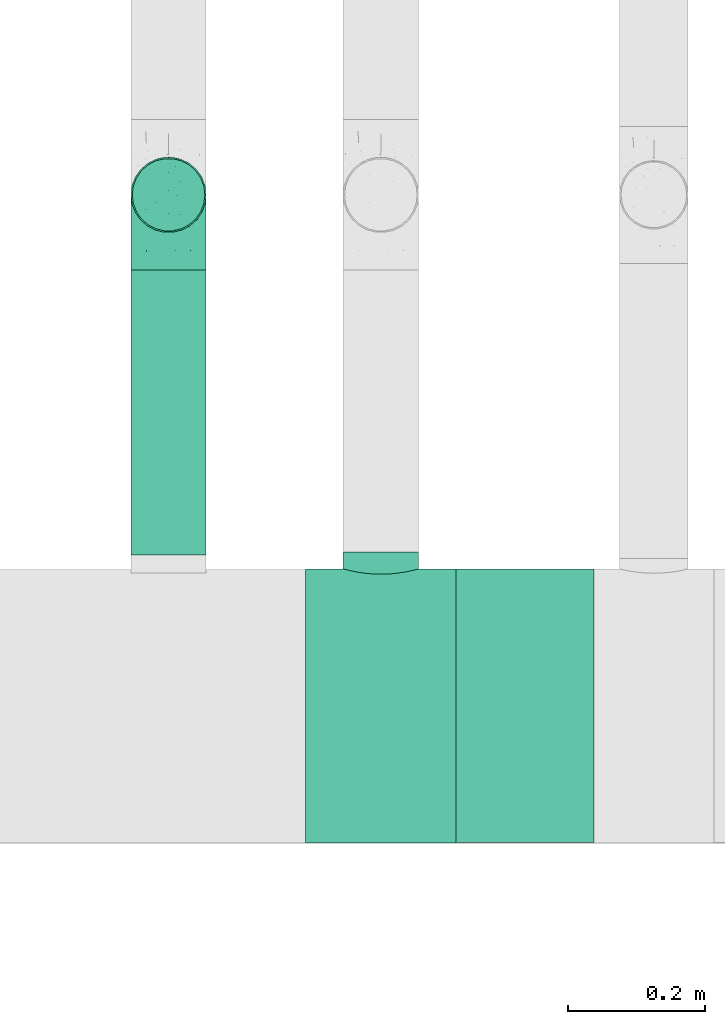
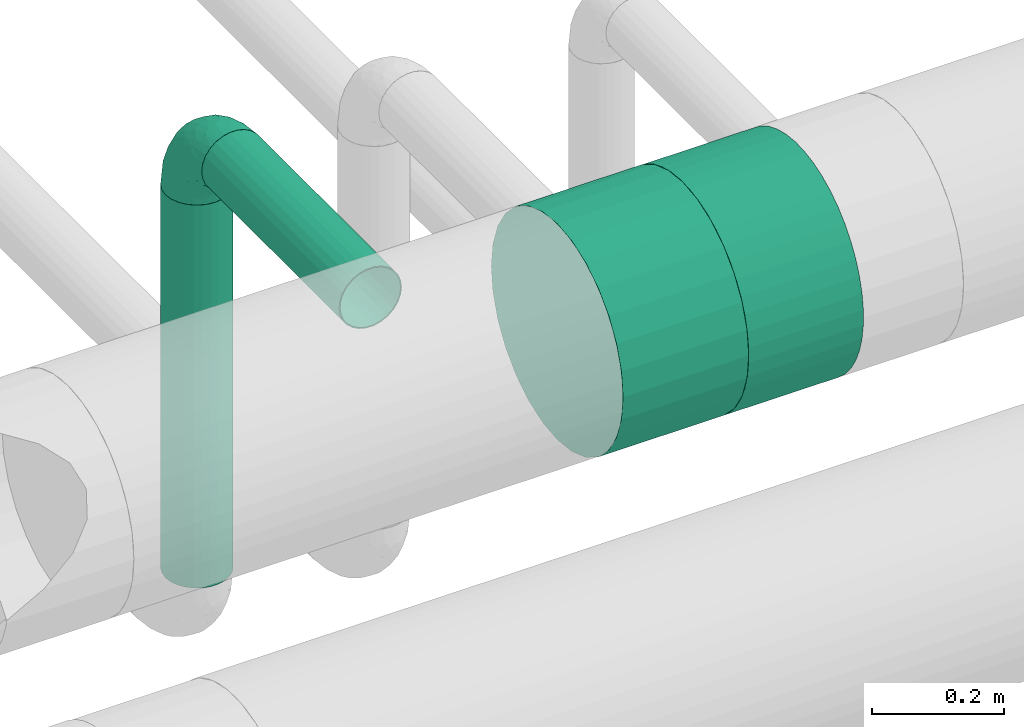
# One storey, part 80 of 91: 3 flow segments, 2 flow fittings.
"""IFC2X3 building model written with IfcOpenShell, lengths in millimetres."""

from ifc_helpers import new_model, entity, si_unit, converted_unit, derived_unit, direction, frame, origin_with_axes, origin_2d_with_axis, place, context, subcontext, project, spatial, hollow_circle, extrude, open_shell, surface_model, source, transform, mapped, material, layer, layer_set, layer_usage, type_object, element, save


model = new_model("IFC2X3")

# Units and contexts
model_context = context("Model", 3, precision=1e-05, world=origin_with_axes(), true_north=direction((0.0, 1.0)))
body_context = subcontext(model_context, "Body", "Model", "MODEL_VIEW")
ifc_project = project(units=[si_unit("AREAUNIT", "SQUARE_METRE"), si_unit("VOLUMEUNIT", "CUBIC_METRE", prefix="DECI"), si_unit("TIMEUNIT", "SECOND"), si_unit("THERMODYNAMICTEMPERATUREUNIT", "DEGREE_CELSIUS"), si_unit("PRESSUREUNIT", "PASCAL"), si_unit("MASSUNIT", "GRAM", prefix="KILO"), si_unit("LENGTHUNIT", "METRE", prefix="MILLI"), si_unit("POWERUNIT", "WATT"), si_unit("ELECTRICCURRENTUNIT", "AMPERE"), si_unit("ELECTRICVOLTAGEUNIT", "VOLT"), derived_unit("VOLUMETRICFLOWRATEUNIT", [(si_unit("VOLUMEUNIT", "CUBIC_METRE", prefix="DECI"), 1), (si_unit("TIMEUNIT", "SECOND"), -1)]), derived_unit("LINEARVELOCITYUNIT", [(si_unit("LENGTHUNIT", "METRE"), 1), (si_unit("TIMEUNIT", "SECOND"), -1)]), derived_unit("MASSDENSITYUNIT", [(si_unit("MASSUNIT", "GRAM", prefix="KILO"), 1), (si_unit("VOLUMEUNIT", "CUBIC_METRE"), -1)]), converted_unit("PLANEANGLEUNIT", "DEGREE", entity("IfcRatioMeasure", 0.01745), si_unit("PLANEANGLEUNIT", "RADIAN"), dimensions=[0, 0, 0, 0, 0, 0, 0])], contexts=[model_context])

# Site, building, storey
site_placement = place(None, origin_with_axes())
site = spatial("IfcSite", under=ifc_project, at=site_placement, CompositionType="ELEMENT")
building_placement = place(site_placement, origin_with_axes())
building = spatial("IfcBuilding", under=site, at=building_placement, Name="mc-building", CompositionType="ELEMENT")
storey_placement = place(building_placement, frame((0.0, 0.0, 8700.0), z_axis=(0.0, 0.0, 1.0), x_axis=(1.0, 0.0, 0.0)))
storey = spatial("IfcBuildingStorey", under=building, at=storey_placement, CompositionType="ELEMENT", Elevation=8700.0)

# Flow fitting
duct_fitting_type_1 = type_object("IfcDuctFittingType", PredefinedType="JUNCTION")
shared_shape_1 = source(origin_with_axes(), body_context, "Body", "SurfaceModel", [
    surface_model("IfcShellBasedSurfaceModel", [(0.0, -225.0, -55.0), (14.23505, -225.0, -53.12592), (-14.23505, -225.0, -53.12592), (-53.12592, -225.0, 14.23505), (-27.5, -225.0, -47.63139), (-47.63139, -225.0, -27.5), (-38.89087, -225.0, -38.89087), (55.0, -225.0, 0.0), (53.12592, -225.0, 14.23505), (38.89087, -225.0, -38.89087), (27.5, -225.0, -47.63139), (53.12592, -225.0, -14.23505), (47.63139, -225.0, -27.5), (-53.12592, -225.0, -14.23505), (-47.63139, -225.0, 27.5), (-38.89087, -225.0, 38.89087), (14.23505, -225.0, 53.12592), (-27.5, -225.0, 47.63139), (-14.23505, -225.0, 53.12592), (47.63139, -225.0, 27.5), (38.89087, -225.0, 38.89087), (27.5, -225.0, 47.63139), (0.0, -225.0, 55.0), (-55.0, -225.0, 0.0), (0.0, -192.28884, 55.0), (-12.29394, -192.68144, 53.60839), (-23.92751, -193.77184, 49.52246), (-34.31923, -195.32745, 42.97895), (-42.9874, -197.03532, 34.30865), (-49.52973, -198.56533, 23.91246), (-53.61252, -199.6229, 12.27592), (-55.0, -200.0, 0.0), (-49.52091, -198.56313, -23.93071), (-42.97449, -197.0325, -34.32482), (-53.60826, -199.62175, -12.29447), (-34.30293, -195.32458, -42.99196), (-23.90904, -193.76957, -49.53138), (-12.27509, -192.68024, -53.61271), (0.0, -192.28884, -55.0), (12.29394, -192.68144, -53.60839), (23.92751, -193.77184, -49.52246), (34.31923, -195.32745, -42.97895), (42.9874, -197.03532, -34.30865), (49.52973, -198.56533, -23.91246), (53.61252, -199.6229, -12.27592), (55.0, -200.0, 0.0), (49.52973, -198.56533, 23.91246), (42.9874, -197.03532, 34.30865), (53.61252, -199.6229, 12.27592), (34.31923, -195.32745, 42.97895), (23.92751, -193.77184, 49.52246), (12.29394, -192.68144, 53.60839), (-110.0, 0.0, -200.0), (-110.0, -44.50419, -194.98559), (-110.0, 44.50419, -194.98559), (-110.0, 194.98559, 44.50419), (-110.0, 86.77674, -180.19378), (-110.0, 180.19378, -86.77674), (-110.0, 156.36629, -124.69796), (-110.0, 124.69796, -156.36629), (-110.0, -200.0, 0.0), (-110.0, -194.98559, 44.50419), (-110.0, -124.69796, -156.36629), (-110.0, -86.77674, -180.19378), (-110.0, -156.36629, -124.69796), (-110.0, -180.19378, -86.77674), (-110.0, -194.98559, -44.50419), (-110.0, 194.98559, -44.50419), (-110.0, 180.19378, 86.77674), (-110.0, 156.36629, 124.69796), (-110.0, 86.77674, 180.19378), (-110.0, 124.69796, 156.36629), (-110.0, 44.50419, 194.98559), (-110.0, 0.0, 200.0), (-110.0, -156.36629, 124.69796), (-110.0, -180.19378, 86.77674), (-110.0, -86.77674, 180.19378), (-110.0, -44.50419, 194.98559), (-110.0, -124.69796, 156.36629), (-110.0, 200.0, 0.0), (110.0, 0.0, -200.0), (110.0, 44.50419, -194.98559), (110.0, 86.77674, -180.19378), (110.0, 200.0, 0.0), (110.0, 156.36629, -124.69796), (110.0, 180.19378, -86.77674), (110.0, 124.69796, -156.36629), (110.0, -156.36629, -124.69796), (110.0, -194.98559, 44.50419), (110.0, -86.77674, -180.19378), (110.0, -44.50419, -194.98559), (110.0, -124.69796, -156.36629), (110.0, -180.19378, -86.77674), (110.0, -194.98559, -44.50419), (110.0, -200.0, 0.0), (110.0, 194.98559, -44.50419), (110.0, 194.98559, 44.50419), (110.0, 180.19378, 86.77674), (110.0, 156.36629, 124.69796), (110.0, 124.69796, 156.36629), (110.0, 86.77674, 180.19378), (110.0, 44.50419, 194.98559), (110.0, -156.36629, 124.69796), (110.0, -180.19378, 86.77674), (110.0, -124.69796, 156.36629), (110.0, -86.77674, 180.19378), (110.0, -44.50419, 194.98559), (110.0, 0.0, 200.0), (-110.0, -197.4928, -22.25209), (110.0, -197.4928, -22.25209), (110.0, -197.4928, 22.25209), (-110.0, -197.4928, 22.25209)], [open_shell([[[0, 1, 2]], [[2, 3, 4]], [[5, 6, 3]], [[6, 4, 3]], [[2, 7, 8]], [[9, 7, 10]], [[1, 10, 7]], [[11, 7, 12]], [[9, 12, 7]], [[7, 2, 1]], [[5, 3, 13]], [[2, 14, 3]], [[2, 15, 14]], [[2, 16, 17]], [[17, 15, 2]], [[16, 18, 17]], [[2, 8, 19]], [[2, 19, 20]], [[2, 20, 21]], [[16, 2, 21]], [[16, 22, 18]], [[23, 13, 3]], [[22, 24, 25]], [[18, 25, 26]], [[22, 25, 18]], [[17, 27, 15]], [[17, 18, 26]], [[27, 17, 26]], [[28, 29, 14]], [[30, 31, 23]], [[29, 30, 3]], [[15, 28, 14]], [[3, 14, 29]], [[23, 3, 30]], [[28, 15, 27]], [[32, 33, 5]], [[34, 32, 13]], [[31, 34, 23]], [[23, 34, 13]], [[32, 5, 13]], [[33, 6, 5]], [[4, 35, 36]], [[36, 37, 2]], [[38, 0, 37]], [[4, 6, 35]], [[2, 4, 36]], [[37, 0, 2]], [[35, 6, 33]], [[0, 38, 39]], [[1, 39, 40]], [[0, 39, 1]], [[10, 41, 9]], [[10, 1, 40]], [[41, 10, 40]], [[42, 43, 12]], [[44, 45, 7]], [[43, 44, 11]], [[9, 42, 12]], [[11, 12, 43]], [[7, 11, 44]], [[42, 9, 41]], [[46, 47, 19]], [[48, 46, 8]], [[45, 48, 7]], [[7, 48, 8]], [[46, 19, 8]], [[47, 20, 19]], [[21, 49, 50]], [[50, 51, 16]], [[24, 22, 51]], [[20, 49, 21]], [[16, 21, 50]], [[22, 16, 51]], [[49, 20, 47]], [[52, 53, 54]], [[54, 55, 56]], [[55, 57, 58]], [[58, 59, 55]], [[59, 56, 55]], [[54, 60, 61]], [[62, 60, 63]], [[54, 53, 63]], [[60, 64, 65]], [[65, 66, 60]], [[60, 62, 64]], [[63, 60, 54]], [[55, 67, 57]], [[54, 68, 55]], [[54, 69, 68]], [[70, 71, 69]], [[70, 54, 72]], [[70, 69, 54]], [[72, 54, 73]], [[74, 73, 75]], [[54, 61, 75]], [[76, 77, 73]], [[73, 78, 76]], [[74, 78, 73]], [[54, 75, 73]], [[79, 67, 55]], [[80, 81, 82]], [[83, 80, 82]], [[84, 85, 83]], [[83, 86, 84]], [[83, 82, 86]], [[87, 80, 88]], [[80, 89, 90]], [[80, 91, 89]], [[91, 80, 87]], [[87, 88, 92]], [[93, 92, 88]], [[93, 88, 94]], [[85, 95, 83]], [[83, 96, 97]], [[98, 80, 97]], [[98, 99, 100]], [[80, 100, 101]], [[80, 98, 100]], [[80, 101, 102]], [[102, 103, 80]], [[88, 80, 103]], [[104, 102, 101]], [[104, 101, 105]], [[101, 106, 105]], [[101, 107, 106]], [[83, 97, 80]], [[72, 107, 101]], [[70, 101, 100]], [[71, 100, 99]], [[73, 107, 72]], [[72, 101, 70]], [[100, 71, 70]], [[99, 69, 71]], [[68, 98, 97]], [[55, 97, 96]], [[79, 96, 83]], [[69, 98, 68]], [[68, 97, 55]], [[96, 79, 55]], [[98, 69, 99]], [[83, 95, 79]], [[85, 84, 58]], [[95, 85, 67]], [[67, 79, 95]], [[58, 57, 85]], [[67, 85, 57]], [[84, 59, 58]], [[56, 86, 82]], [[54, 82, 81]], [[52, 81, 80]], [[59, 86, 56]], [[56, 82, 54]], [[81, 52, 54]], [[86, 59, 84]], [[90, 53, 80]], [[89, 63, 90]], [[65, 87, 92]], [[89, 91, 62]], [[87, 64, 91]], [[92, 40, 39]], [[39, 38, 92]], [[53, 90, 63]], [[62, 63, 89]], [[53, 52, 80]], [[38, 37, 65]], [[34, 108, 32]], [[64, 87, 65]], [[37, 36, 65]], [[64, 62, 91]], [[38, 65, 92]], [[42, 109, 43]], [[93, 42, 41]], [[93, 109, 42]], [[41, 40, 93]], [[93, 40, 92]], [[94, 45, 44]], [[43, 109, 44]], [[44, 109, 94]], [[36, 35, 66]], [[33, 32, 108]], [[33, 66, 35]], [[36, 66, 65]], [[34, 60, 108]], [[31, 60, 34]], [[108, 66, 33]], [[45, 94, 48]], [[94, 110, 48]], [[110, 47, 46]], [[47, 110, 88]], [[49, 47, 88]], [[29, 111, 30]], [[60, 31, 30]], [[111, 60, 30]], [[27, 26, 61]], [[61, 111, 28]], [[61, 28, 27]], [[26, 75, 61]], [[49, 88, 50]], [[51, 103, 24]], [[48, 110, 46]], [[51, 50, 103]], [[74, 103, 102]], [[103, 50, 88]], [[105, 106, 77]], [[76, 104, 105]], [[78, 102, 104]], [[73, 106, 107]], [[25, 24, 75]], [[28, 111, 29]], [[75, 24, 103]], [[74, 75, 103]], [[25, 75, 26]], [[102, 78, 74]], [[104, 76, 78]], [[77, 76, 105]], [[106, 73, 77]]])]),
])
flow_fitting_1_placement = place(storey_placement, frame((30674.56773, 10080.96985, 1344.0), z_axis=(0.0, 0.0, 1.0), x_axis=(-1.0, 0.0, 0.0)))
element("IfcFlowFitting", 1, at=flow_fitting_1_placement, inside=storey, type_object=duct_fitting_type_1, context=body_context, shape_type="MappedRepresentation", body=[
    mapped(shared_shape_1, transform((0.0, 0.0, 0.0), scale=1.0)),
])

# Flow segment
ifc_material = material(Name="FZ1")
ifc_layer = layer(ifc_material, 0.0)
ifc_layer_set = layer_set([ifc_layer], Name="FZ1")
ifc_layer_usage = layer_usage(ifc_layer_set, "AXIS1", "POSITIVE", 0.0)
duct_segment_type_1 = type_object("IfcDuctSegmentType", PredefinedType="RIGIDSEGMENT")
shared_shape_2 = source(origin_with_axes(), body_context, "Body", "SweptSolid", [
    extrude(hollow_circle(Radius=55.0, WallThickness=2.0, at=origin_2d_with_axis()), frame((0.0, 0.0, 0.0), z_axis=(1.0, 0.0, 0.0), x_axis=(0.0, 1.0, 0.0)), (0.0, 0.0, 1.0), 709.0),
])
flow_segment_1_placement = place(storey_placement, frame((30364.56773, 10827.25695, 1234.0), z_axis=(0.0, 1.0, 0.0), x_axis=(0.0, 0.0, -1.0)))
element("IfcFlowSegment", 2, at=flow_segment_1_placement, inside=storey, type_object=duct_segment_type_1, material=ifc_layer_usage, context=body_context, shape_type="MappedRepresentation", body=[
    mapped(shared_shape_2, transform((0.0, 0.0, 0.0), scale=1.0)),
])

# Flow fitting
duct_fitting_type_2 = type_object("IfcDuctFittingType", Name="BU", PredefinedType="BEND")
shared_shape_3 = source(origin_with_axes(), body_context, "Body", "SurfaceModel", [
    surface_model("IfcShellBasedSurfaceModel", [(-110.0, 0.0, -55.0), (-110.0, -14.23505, -53.12592), (-110.0, 14.23505, -53.12592), (-110.0, 53.12592, 14.23505), (-110.0, 27.5, -47.63139), (-110.0, 38.89087, -38.89087), (-110.0, -55.0, 0.0), (-110.0, -53.12592, 14.23505), (-110.0, -38.89087, -38.89087), (-110.0, -27.5, -47.63139), (-110.0, -53.12592, -14.23505), (-110.0, -47.63139, -27.5), (-110.0, -14.23505, 53.12592), (-110.0, 14.23505, 53.12592), (-110.0, 27.5, 47.63139), (-110.0, -47.63139, 27.5), (-110.0, -38.89087, 38.89087), (-110.0, -27.5, 47.63139), (-110.0, 0.0, 55.0), (-110.0, 55.0, 0.0), (-110.0, 53.12592, -14.23505), (-110.0, 47.63139, -27.5), (-110.0, 47.63139, 27.5), (-110.0, 38.89087, 38.89087), (-14.23505, 110.0, -53.12592), (-55.0, 110.0, 0.0), (0.0, 110.0, -55.0), (-27.5, 110.0, -47.63139), (-38.89087, 110.0, -38.89087), (-47.63139, 110.0, -27.5), (38.89087, 110.0, -38.89087), (53.12592, 110.0, 14.23505), (27.5, 110.0, -47.63139), (14.23505, 110.0, -53.12592), (47.63139, 110.0, -27.5), (53.12592, 110.0, -14.23505), (55.0, 110.0, 0.0), (-53.12592, 110.0, -14.23505), (-53.12592, 110.0, 14.23505), (-47.63139, 110.0, 27.5), (-38.89087, 110.0, 38.89087), (-27.5, 110.0, 47.63139), (0.0, 110.0, 55.0), (-14.23505, 110.0, 53.12592), (38.89087, 110.0, 38.89087), (47.63139, 110.0, 27.5), (27.5, 110.0, 47.63139), (14.23505, 110.0, 53.12592), (-64.21732, 48.68956, 43.63444), (-76.6405, 38.18013, 45.55988), (-60.44912, 32.56953, 51.94617), (-76.00813, 5.38378, 55.0), (-90.15553, 11.94394, 54.09138), (-78.5998, 26.77405, 50.81338), (-70.18771, 18.55163, 54.03432), (-75.55424, 54.2118, 32.41257), (-93.27622, 45.77614, 33.48188), (-96.12334, 22.13664, 50.81337), (-21.00813, 45.34362, 55.0), (-18.36258, 70.48427, 54.04484), (-32.04182, 59.64019, 52.24446), (-63.88653, 74.77858, 17.99134), (-74.66383, 63.08407, 19.92123), (-63.60674, 66.07878, 29.97482), (-99.597, 52.72185, 18.52927), (-93.11138, 56.59448, 10.50359), (-98.21577, 57.34403, 0.0), (-53.42855, 92.60092, 21.04759), (-88.54852, 54.8376, 21.04759), (-11.86161, 90.23965, 54.10313), (-5.38378, 76.00813, 55.0), (-57.34403, 98.21577, 0.0), (-56.64619, 93.12774, 10.22088), (-45.34362, 21.00813, 55.0), (-44.60838, 44.60838, 52.13415), (-92.68484, 35.46673, 43.63443), (-22.25266, 95.40765, 50.81337), (-35.97783, 90.61597, 43.63443), (-43.70931, 69.58671, 44.47149), (-27.23711, 77.39884, 50.81337), (-57.2828, 79.3123, 24.9774), (-58.67786, 84.31125, 16.04456), (-82.93277, 60.36161, 12.91784), (-49.88337, 54.51816, 47.224), (-74.57753, 66.83759, 9.55742), (-45.35812, 94.97281, 33.48188), (-59.18663, 88.95241, 0.0), (-51.517, 78.6292, 33.48188), (-65.14788, 80.03077, 0.0), (-56.45322, 62.06476, 39.63545), (-88.95241, 59.18663, 0.0), (-71.10913, 71.10913, 0.0), (-80.03077, 65.14788, 0.0), (-94.9309, 45.36788, -33.48188), (-93.11358, 56.60141, -10.46614), (-99.64997, 52.79499, -18.30015), (-90.20425, 36.08686, -43.63443), (-79.99933, 46.56772, -37.92748), (-76.00813, 5.38378, -55.0), (-72.75364, 19.68651, -53.60527), (-45.34362, 21.00813, -55.0), (-21.91957, 65.12078, -53.85897), (-5.38378, 76.00813, -55.0), (-21.00813, 45.34362, -55.0), (-35.41876, 92.89265, -43.63443), (-91.10309, 11.02766, -54.21832), (-45.77614, 93.27622, -33.48188), (-90.50474, 23.21022, -50.81337), (-70.92854, 33.31794, -49.51754), (-78.52933, 63.35627, -11.73997), (-24.91508, 84.05606, -50.81337), (-88.78941, 54.74452, -21.04759), (-69.59921, 57.34866, -33.48187), (-73.36422, 62.46673, -22.94182), (-63.49062, 67.59111, -28.46929), (-56.59448, 93.11138, -10.50359), (-54.8376, 88.54852, -21.04759), (-54.10679, 75.85581, -32.31867), (-57.75956, 31.09612, -52.80882), (-52.72185, 99.597, -18.52927), (-12.62913, 89.46304, -53.99097), (-34.46825, 66.46123, -50.04329), (-43.9837, 43.9837, -52.42279), (-65.78527, 72.58348, -17.68796), (-70.34468, 43.65295, -44.21951), (-57.47001, 51.99467, -44.91465), (-60.72547, 82.29174, -12.88567), (-42.34915, 74.24548, -43.63444), (-57.25194, 63.5016, -38.08211), (-80.95344, 53.56991, -29.32027), (-52.32891, 4.55257, -54.0482), (32.52942, 47.13398, -30.48571), (14.88266, 20.92917, -33.7947), (14.95561, 36.05775, -42.26543), (30.24048, 70.09027, -41.7461), (19.3559, 65.35825, -48.00507), (-70.35075, -46.44478, -19.5952), (-47.13398, -32.52942, -30.48571), (-28.49299, -30.5778, -16.4009), (-4.55257, 52.32891, -54.0482), (-22.4954, 22.4954, -53.25347), (-75.47368, -11.22546, -52.60718), (-81.32209, -51.5606, -9.98467), (-80.81763, -41.84862, -32.14655), (-70.09027, -30.24048, -41.7461), (-36.05774, -14.95561, -42.26543), (-9.15831, -10.852, -27.8997), (-65.35825, -19.3559, -48.00507), (11.22546, 75.47368, -52.60718), (3.94376, 43.9333, -50.53315), (-13.39742, 13.39743, -48.13058), (-43.9333, -3.94376, -50.53315), (49.37776, 67.29486, 0.0), (41.8609, 47.82256, -9.92641), (50.20582, 74.51695, -9.9731), (18.93131, 11.7156, -17.56239), (-27.5, -32.89419, 0.0), (-1.23348, -12.25375, -12.18106), (41.84862, 80.81763, -32.14655), (35.70604, 41.31408, -20.38235), (46.44478, 70.35075, -19.5952), (32.89419, 27.5, 0.0), (6.67262, -6.67262, 0.0), (-67.29486, -49.37776, 0.0), (-50.36265, -42.95545, -9.51562), (-5.47251, 5.47251, -39.92906), (-70.35075, -46.44478, 19.5952), (-74.51695, -50.20582, 9.9731), (-41.31407, -35.70604, 20.38235), (-47.13398, -32.52942, 30.48571), (-80.81763, -41.84862, 32.14655), (-4.55257, 52.32891, 54.0482), (11.22546, 75.47368, 52.60718), (-43.9333, -3.94376, 50.53315), (-65.35825, -19.3559, 48.00507), (-36.05774, -14.95561, 42.26543), (-70.09027, -30.24048, 41.7461), (-11.7156, -18.93131, 17.56239), (30.5778, 28.49299, 16.4009), (12.25375, 1.23348, 12.18106), (51.5606, 81.32209, 9.98467), (42.95545, 50.36265, 9.51562), (-75.47368, -11.22546, 52.60718), (-52.32891, 4.55257, 54.0482), (3.94376, 43.9333, 50.53315), (-22.4954, 22.4954, 53.25347), (-13.39742, 13.39743, 48.13058), (10.852, 9.15831, 27.8997), (-20.92916, -14.88266, 33.79469), (-47.82256, -41.8609, 9.92641), (32.52942, 47.13398, 30.48571), (46.44478, 70.35075, 19.5952), (41.84862, 80.81763, 32.14655), (30.24048, 70.09027, 41.7461), (19.3559, 65.35825, 48.00507), (14.95561, 36.05775, 42.26543), (-5.47251, 5.47251, 39.92906)], [open_shell([[[0, 1, 2]], [[2, 3, 4]], [[4, 3, 5]], [[2, 6, 7]], [[8, 6, 9]], [[1, 9, 6]], [[10, 6, 11]], [[8, 11, 6]], [[6, 2, 1]], [[12, 13, 14]], [[15, 2, 7]], [[16, 17, 2]], [[2, 17, 12]], [[12, 18, 13]], [[19, 20, 3]], [[5, 3, 21]], [[20, 21, 3]], [[22, 3, 2]], [[23, 22, 2]], [[12, 14, 2]], [[2, 14, 23]], [[15, 16, 2]], [[24, 25, 26]], [[27, 25, 24]], [[25, 28, 29]], [[28, 25, 27]], [[30, 26, 31]], [[26, 30, 32]], [[32, 33, 26]], [[34, 31, 35]], [[31, 34, 30]], [[35, 31, 36]], [[29, 37, 25]], [[38, 39, 26]], [[39, 40, 26]], [[41, 42, 40]], [[42, 26, 40]], [[42, 41, 43]], [[26, 44, 45]], [[31, 26, 45]], [[26, 46, 44]], [[47, 46, 26]], [[42, 47, 26]], [[25, 38, 26]], [[48, 49, 50]], [[18, 51, 52]], [[53, 54, 50]], [[55, 56, 49]], [[56, 22, 23]], [[13, 57, 14]], [[58, 59, 60]], [[61, 62, 63]], [[3, 64, 65]], [[53, 52, 54]], [[3, 65, 66]], [[67, 39, 38]], [[56, 68, 64]], [[65, 64, 68]], [[69, 59, 70]], [[38, 71, 72]], [[73, 58, 74]], [[75, 49, 56]], [[76, 69, 43]], [[53, 57, 52]], [[77, 78, 79]], [[41, 76, 43]], [[43, 69, 42]], [[55, 68, 56]], [[23, 14, 75]], [[76, 77, 79]], [[80, 67, 81]], [[62, 82, 68]], [[60, 78, 83]], [[62, 84, 82]], [[85, 77, 40]], [[81, 67, 72]], [[86, 72, 71]], [[87, 85, 67]], [[61, 81, 88]], [[77, 41, 40]], [[78, 77, 87]], [[23, 75, 56]], [[83, 89, 48]], [[85, 40, 39]], [[62, 68, 55]], [[89, 87, 63]], [[83, 48, 50]], [[57, 75, 14]], [[49, 75, 53]], [[67, 85, 39]], [[87, 77, 85]], [[63, 62, 55]], [[89, 55, 48]], [[80, 63, 87]], [[66, 65, 90]], [[66, 19, 3]], [[84, 91, 92]], [[92, 90, 82]], [[65, 82, 90]], [[61, 84, 62]], [[92, 82, 84]], [[68, 82, 65]], [[3, 22, 64]], [[56, 64, 22]], [[38, 25, 71]], [[81, 72, 86]], [[38, 72, 67]], [[91, 61, 88]], [[80, 81, 61]], [[63, 80, 61]], [[67, 80, 87]], [[77, 76, 41]], [[79, 59, 69]], [[79, 69, 76]], [[42, 69, 70]], [[60, 59, 79]], [[58, 70, 59]], [[78, 60, 79]], [[58, 60, 74]], [[52, 57, 13]], [[75, 57, 53]], [[18, 52, 13]], [[52, 51, 54]], [[51, 73, 54]], [[50, 73, 74]], [[73, 50, 54]], [[50, 74, 83]], [[60, 83, 74]], [[89, 83, 78]], [[87, 89, 78]], [[55, 89, 63]], [[50, 49, 53]], [[55, 49, 48]], [[81, 86, 88]], [[91, 84, 61]], [[5, 21, 93]], [[90, 94, 66]], [[20, 94, 95]], [[96, 93, 97]], [[98, 99, 100]], [[96, 4, 5]], [[101, 102, 103]], [[28, 27, 104]], [[2, 105, 0]], [[104, 106, 28]], [[99, 105, 107]], [[108, 107, 96]], [[90, 109, 94]], [[107, 2, 4]], [[20, 66, 94]], [[27, 24, 110]], [[109, 111, 94]], [[112, 113, 114]], [[37, 115, 71]], [[116, 106, 117]], [[99, 118, 100]], [[116, 115, 119]], [[37, 119, 115]], [[24, 120, 110]], [[121, 110, 101]], [[119, 106, 116]], [[101, 110, 120]], [[122, 103, 100]], [[117, 123, 116]], [[124, 125, 108]], [[115, 116, 126]], [[106, 29, 28]], [[26, 102, 120]], [[127, 104, 110]], [[97, 124, 96]], [[125, 122, 118]], [[128, 127, 125]], [[96, 5, 93]], [[115, 126, 86]], [[117, 106, 127]], [[111, 113, 129]], [[95, 93, 21]], [[97, 129, 112]], [[110, 104, 27]], [[106, 104, 127]], [[96, 107, 4]], [[99, 107, 108]], [[99, 108, 118]], [[105, 99, 98]], [[112, 114, 128]], [[121, 125, 127]], [[20, 19, 66]], [[109, 90, 92]], [[94, 111, 95]], [[91, 123, 109]], [[129, 113, 112]], [[93, 95, 111]], [[21, 20, 95]], [[71, 115, 86]], [[71, 25, 37]], [[123, 91, 88]], [[126, 116, 123]], [[123, 88, 126]], [[86, 126, 88]], [[37, 29, 119]], [[106, 119, 29]], [[129, 93, 111]], [[124, 112, 125]], [[0, 105, 98]], [[107, 105, 2]], [[125, 118, 108]], [[100, 118, 122]], [[93, 129, 97]], [[113, 111, 109]], [[109, 123, 113]], [[114, 123, 117]], [[123, 114, 113]], [[128, 114, 117]], [[127, 128, 117]], [[112, 128, 125]], [[103, 122, 101]], [[110, 121, 127]], [[101, 122, 121]], [[125, 121, 122]], [[26, 120, 24]], [[101, 120, 102]], [[96, 124, 108]], [[92, 91, 109]], [[112, 124, 97]], [[100, 130, 98]], [[131, 132, 133]], [[32, 134, 135]], [[136, 137, 138]], [[139, 140, 103]], [[98, 141, 0]], [[142, 10, 136]], [[143, 144, 137]], [[6, 10, 142]], [[137, 145, 146]], [[144, 147, 145]], [[143, 136, 11]], [[11, 136, 10]], [[8, 143, 11]], [[148, 149, 139]], [[8, 9, 144]], [[9, 1, 147]], [[130, 141, 98]], [[103, 140, 100]], [[148, 135, 149]], [[150, 151, 140]], [[152, 153, 154]], [[130, 140, 151]], [[148, 26, 33]], [[147, 1, 141]], [[155, 146, 132]], [[156, 138, 157]], [[134, 30, 158]], [[150, 140, 149]], [[158, 30, 34]], [[30, 134, 32]], [[153, 159, 160]], [[131, 160, 159]], [[144, 145, 137]], [[36, 152, 154]], [[146, 138, 137]], [[155, 161, 162]], [[158, 160, 131]], [[133, 149, 135]], [[156, 163, 164]], [[163, 142, 164]], [[139, 103, 102]], [[153, 152, 161]], [[34, 35, 160]], [[162, 157, 155]], [[132, 165, 133]], [[157, 146, 155]], [[140, 130, 100]], [[141, 130, 151]], [[141, 151, 147]], [[141, 1, 0]], [[102, 26, 148]], [[140, 139, 149]], [[102, 148, 139]], [[135, 33, 32]], [[151, 150, 145]], [[9, 147, 144]], [[151, 145, 147]], [[145, 165, 146]], [[135, 148, 33]], [[133, 135, 134]], [[131, 133, 134]], [[133, 165, 150]], [[133, 150, 149]], [[145, 150, 165]], [[132, 131, 159]], [[146, 165, 132]], [[160, 158, 34]], [[134, 158, 131]], [[144, 143, 8]], [[136, 143, 137]], [[155, 153, 161]], [[154, 153, 160]], [[153, 155, 159]], [[132, 159, 155]], [[160, 35, 154]], [[36, 154, 35]], [[164, 136, 138]], [[6, 142, 163]], [[136, 164, 142]], [[156, 164, 138]], [[156, 157, 162]], [[146, 157, 138]], [[15, 7, 166]], [[6, 163, 167]], [[168, 169, 166]], [[166, 169, 170]], [[171, 172, 70]], [[173, 174, 175]], [[17, 176, 174]], [[177, 156, 162]], [[176, 16, 170]], [[170, 16, 15]], [[161, 178, 179]], [[152, 180, 181]], [[182, 173, 183]], [[18, 12, 182]], [[184, 185, 186]], [[183, 185, 73]], [[183, 73, 51]], [[177, 187, 188]], [[189, 168, 166]], [[187, 178, 190]], [[16, 176, 17]], [[161, 152, 181]], [[45, 191, 31]], [[45, 44, 192]], [[192, 191, 45]], [[180, 36, 31]], [[193, 194, 195]], [[46, 47, 194]], [[193, 195, 190]], [[193, 44, 46]], [[172, 42, 70]], [[185, 58, 73]], [[189, 163, 156]], [[163, 189, 167]], [[70, 58, 171]], [[184, 171, 185]], [[169, 188, 175]], [[180, 31, 191]], [[192, 193, 190]], [[191, 190, 178]], [[182, 174, 173]], [[194, 47, 172]], [[190, 195, 187]], [[186, 185, 173]], [[162, 179, 177]], [[188, 196, 175]], [[179, 187, 177]], [[185, 171, 58]], [[172, 171, 184]], [[172, 184, 194]], [[172, 47, 42]], [[51, 18, 182]], [[185, 183, 173]], [[51, 182, 183]], [[174, 12, 17]], [[184, 186, 195]], [[46, 194, 193]], [[184, 195, 194]], [[195, 196, 187]], [[174, 182, 12]], [[175, 174, 176]], [[169, 175, 176]], [[175, 196, 186]], [[175, 186, 173]], [[195, 186, 196]], [[188, 169, 168]], [[187, 196, 188]], [[166, 170, 15]], [[176, 170, 169]], [[193, 192, 44]], [[191, 192, 190]], [[177, 189, 156]], [[167, 189, 166]], [[189, 177, 168]], [[188, 168, 177]], [[166, 7, 167]], [[6, 167, 7]], [[181, 191, 178]], [[36, 180, 152]], [[191, 181, 180]], [[161, 181, 178]], [[161, 179, 162]], [[187, 179, 178]]])]),
])
flow_fitting_2_placement = place(storey_placement, frame((30364.56773, 10827.25695, 1344.0), z_axis=(1.0, 0.0, 0.0), x_axis=(0.0, 0.0, 1.0)))
element("IfcFlowFitting", 3, at=flow_fitting_2_placement, inside=storey, type_object=duct_fitting_type_2, Name="BU", context=body_context, shape_type="MappedRepresentation", body=[
    mapped(shared_shape_3, transform((0.0, 0.0, 0.0), scale=1.0)),
])

# Flow segments
duct_segment_type_2 = type_object("IfcDuctSegmentType", Name="Safe", PredefinedType="RIGIDSEGMENT")
shared_shape_4 = source(origin_with_axes(), body_context, "Body", "SweptSolid", [
    extrude(hollow_circle(Radius=200.0, WallThickness=2.0, at=origin_2d_with_axis()), frame((0.0, 0.0, 0.0), z_axis=(1.0, 0.0, 0.0), x_axis=(0.0, 1.0, 0.0)), (0.0, 0.0, 1.0), 201.1),
])
flow_segment_2_placement = place(storey_placement, frame((30784.56773, 10080.96985, 1344.0), z_axis=(0.0, 0.0, 1.0), x_axis=(1.0, 0.0, 0.0)))
element("IfcFlowSegment", 4, at=flow_segment_2_placement, inside=storey, type_object=duct_segment_type_2, material=ifc_layer_usage, Name="Safe", context=body_context, shape_type="MappedRepresentation", body=[
    mapped(shared_shape_4, transform((0.0, 0.0, 0.0), scale=1.0)),
])
shared_shape_5 = source(origin_with_axes(), body_context, "Body", "SweptSolid", [
    extrude(hollow_circle(Radius=55.0, WallThickness=2.0, at=origin_2d_with_axis()), frame((0.0, 0.0, 0.0), z_axis=(1.0, 0.0, 0.0), x_axis=(0.0, 1.0, 0.0)), (0.0, 0.0, 1.0), 416.3),
])
flow_segment_3_placement = place(storey_placement, frame((30364.56773, 10300.96985, 1344.0), z_axis=(0.0, 0.0, 1.0), x_axis=(0.0, 1.0, 0.0)))
element("IfcFlowSegment", 5, at=flow_segment_3_placement, inside=storey, type_object=duct_segment_type_1, material=ifc_layer_usage, context=body_context, shape_type="MappedRepresentation", body=[
    mapped(shared_shape_5, transform((0.0, 0.0, 0.0), scale=1.0)),
])

save(model, "model.ifc")
